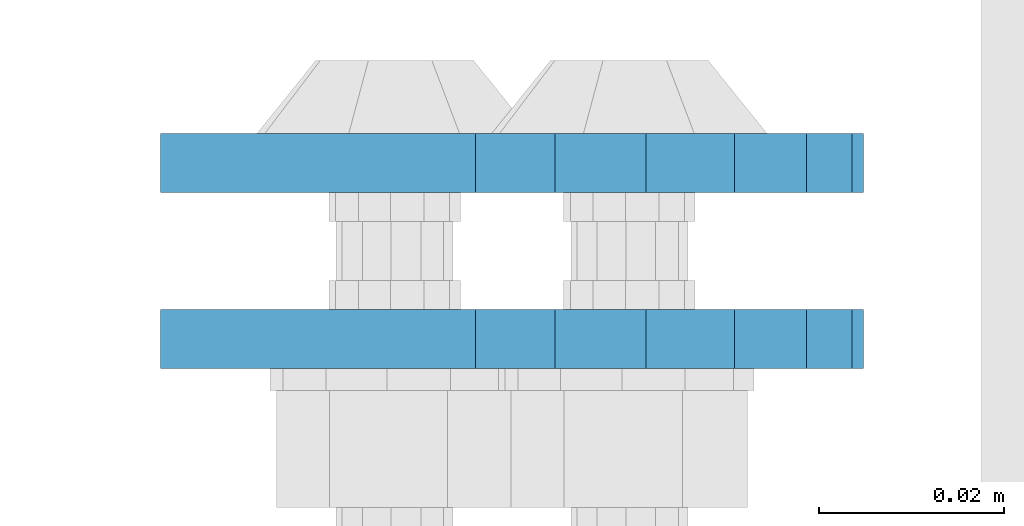
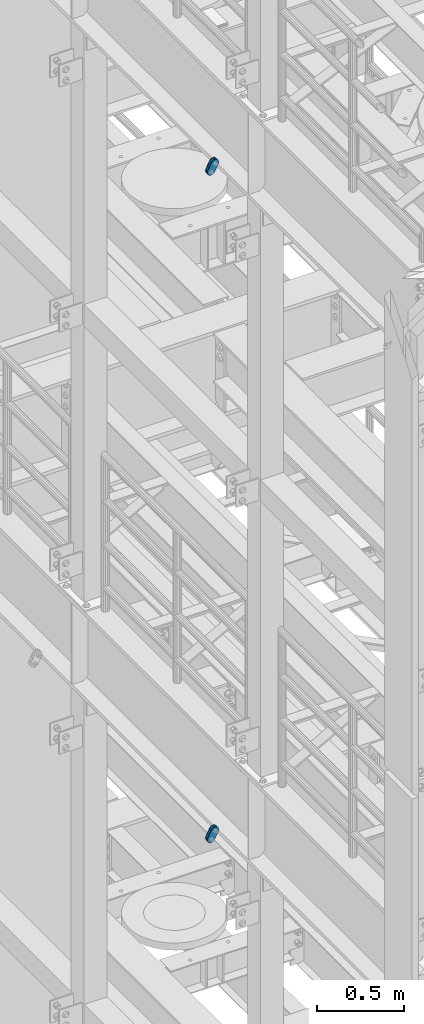
# One storey, part 1478 of 1876: 4 plates, 4 elements without a shape of their own.
"""IFC2X3 building model written with IfcOpenShell, lengths in millimetres."""

from ifc_helpers import new_model, si_unit, frame, origin_with_axes, place, context, subcontext, project, spatial, faceted_brep, material, type_object, element, aggregate, save


model = new_model("IFC2X3")

# Units and contexts
model_context = context("Model", 3, precision=1e-05, world=origin_with_axes())
body_context = subcontext(model_context, "Body", "Model", "MODEL_VIEW")
ifc_project = project(units=[si_unit("LENGTHUNIT", "METRE", prefix="MILLI"), si_unit("AREAUNIT", "SQUARE_METRE"), si_unit("VOLUMEUNIT", "CUBIC_METRE"), si_unit("MASSUNIT", "GRAM", prefix="KILO"), si_unit("TIMEUNIT", "SECOND"), si_unit("PLANEANGLEUNIT", "RADIAN"), si_unit("SOLIDANGLEUNIT", "STERADIAN"), si_unit("THERMODYNAMICTEMPERATUREUNIT", "DEGREE_CELSIUS"), si_unit("LUMINOUSINTENSITYUNIT", "LUMEN")], contexts=[model_context])

# Site, building, storey
site_placement = place(None, origin_with_axes())
site = spatial("IfcSite", under=ifc_project, at=site_placement, CompositionType="ELEMENT")
building_placement = place(site_placement, origin_with_axes())
building = spatial("IfcBuilding", under=site, at=building_placement, Name="Undefined", CompositionType="ELEMENT")
storey_placement = place(building_placement, origin_with_axes())
storey = spatial("IfcBuildingStorey", under=building, at=storey_placement, Name="Undefined", CompositionType="ELEMENT", Elevation=0.0)

# Assembly, plate
assembly_1_placement = place(storey_placement, origin_with_axes())
assembly_1 = element("IfcElementAssembly", 1, at=assembly_1_placement, inside=storey, Name="PLATE", AssemblyPlace="NOTDEFINED", PredefinedType="RIGID_FRAME")
ifc_material = material(Name="STEEL/A36")
plate_type = type_object("IfcPlateType", PredefinedType="NOTDEFINED")
plate_1_placement = place(assembly_1_placement, frame((-354.259224851122, -2549.5249946794, 17725.1776774809), z_axis=(0.894427191199916, 0.0, -0.447213595099958), x_axis=(-0.447213595099961, 6.99999707257306e-09, -0.894427191199915)))
plate_1 = element("IfcPlate", 2, at=plate_1_placement, type_object=plate_type, material=ifc_material, Name="PLATE", context=body_context, shape_type="Brep", body=[
    faceted_brep([(-8.59611645864788e-07, -3.17499999999654, 25.3999987589127), (1.93345873884391, -3.17499999999382, 35.1201580589886), (1.93345873884391, 3.17500000000564, 35.1201580589886), (-8.59611645864788e-07, 3.17500000000382, 25.3999987589132), (7.43948648259902, -3.17499999999109, 43.3605112870105), (7.43948648259902, 3.17500000000928, 43.3605112870105), (15.6798395242777, -3.17499999998654, 48.8665393096448), (15.6798395242777, 3.17500000001382, 48.8665393096448), (25.3999987589095, -3.17499999998199, 50.7999992370592), (25.3999987589095, 3.17500000001837, 50.7999992370592), (82.196130752618, -3.17499999998381, 50.7999992370605), (82.196130752618, 3.17500000001655, 50.7999992370642), (91.9162897887145, -3.17499999997926, 48.8665393918873), (91.9162897887145, 3.1750000000211, 48.8665393918909), (100.156642725027, -3.17499999997472, 43.3605115909359), (100.156642725027, 3.17500000002565, 43.3605115909395), (105.662670525982, -3.17499999997108, 35.1201586546285), (105.662670525986, 3.17500000002929, 35.1201586546358), (107.596130371159, -3.17499999996744, 25.3999996185757), (107.596130371159, 3.17500000003292, 25.3999996185794), (105.662670525981, -3.17499999996471, 15.6798405824902), (105.662670525981, 3.17500000003565, 15.6798405824939), (100.156642725024, -3.17499999996471, 7.43948764618654), (100.156642725025, 3.17500000003565, 7.43948764619017), (91.9162897887127, -3.17499999996562, 1.93345984522784), (91.9162897887127, 3.17500000003474, 1.93345984523148), (82.196130752618, -3.17499999996835, 4.54747350886464e-11), (82.196130752618, 3.1750000000311, 4.91127138957381e-11), (25.399998758905, -3.17499999999018, -8.64019966684282e-12), (25.399998758905, 3.17500000001019, -8.64019966684282e-12), (15.679839921364, -3.17499999999382, 1.9334597629304), (15.679839921364, 3.17500000000655, 1.9334597629304), (7.43948709043525, -3.17499999999654, 7.43948734220839), (7.43948709043525, 3.17500000000382, 7.43948734220885), (1.93345923228208, -3.17499999999654, 15.6798399868012), (1.93345923228208, 3.17500000000291, 15.6798399868012)], [[[0, 1, 2, 3]], [[1, 4, 5, 2]], [[4, 6, 7, 5]], [[6, 8, 9, 7]], [[8, 10, 11, 9]], [[10, 12, 13, 11]], [[12, 14, 15, 13]], [[14, 16, 17, 15]], [[16, 18, 19, 17]], [[18, 20, 21, 19]], [[20, 22, 23, 21]], [[22, 24, 25, 23]], [[24, 26, 27, 25]], [[26, 28, 29, 27]], [[28, 30, 31, 29]], [[30, 32, 33, 31]], [[32, 34, 35, 33]], [[34, 0, 3, 35]], [[5, 7, 9, 11, 13, 15, 17, 19, 21, 23, 25, 27, 29, 31, 33, 35, 3, 2]], [[34, 32, 30, 28, 26, 24, 22, 20, 18, 16, 14, 12, 10, 8, 6, 4, 1, 0]]]),
])
aggregate(assembly_1, [plate_1])

assembly_2_placement = place(storey_placement, origin_with_axes())
assembly_2 = element("IfcElementAssembly", 3, at=assembly_2_placement, inside=storey, Name="PLATE", AssemblyPlace="NOTDEFINED", PredefinedType="RIGID_FRAME")
plate_2_placement = place(assembly_2_placement, frame((-354.259224851122, -2530.46379837472, 17725.1776774809), z_axis=(0.894427191199916, 0.0, -0.447213595099958), x_axis=(-0.447213595099961, 6.99999707257306e-09, -0.894427191199915)))
plate_2 = element("IfcPlate", 4, at=plate_2_placement, type_object=plate_type, material=ifc_material, Name="PLATE", context=body_context, shape_type="Brep", body=[
    faceted_brep([(-8.59611645864788e-07, -3.17499999999654, 25.3999987589127), (1.93345873884391, -3.17499999999382, 35.1201580589886), (1.93345873884391, 3.17500000000564, 35.1201580589886), (-8.59611645864788e-07, 3.17500000000382, 25.3999987589132), (7.43948648259902, -3.17499999999109, 43.3605112870105), (7.43948648259902, 3.17500000000928, 43.3605112870105), (15.6798395242777, -3.17499999998654, 48.8665393096448), (15.6798395242777, 3.17500000001382, 48.8665393096448), (25.3999987589095, -3.17499999998199, 50.7999992370592), (25.3999987589095, 3.17500000001837, 50.7999992370592), (82.196130752618, -3.17499999998381, 50.7999992370605), (82.196130752618, 3.17500000001655, 50.7999992370642), (91.9162897887145, -3.17499999997926, 48.8665393918873), (91.9162897887145, 3.1750000000211, 48.8665393918909), (100.156642725027, -3.17499999997472, 43.3605115909359), (100.156642725027, 3.17500000002565, 43.3605115909395), (105.662670525982, -3.17499999997108, 35.1201586546285), (105.662670525986, 3.17500000002929, 35.1201586546358), (107.596130371159, -3.17499999996744, 25.3999996185757), (107.596130371159, 3.17500000003292, 25.3999996185794), (105.662670525981, -3.17499999996471, 15.6798405824902), (105.662670525981, 3.17500000003565, 15.6798405824939), (100.156642725024, -3.17499999996471, 7.43948764618654), (100.156642725025, 3.17500000003565, 7.43948764619017), (91.9162897887127, -3.17499999996562, 1.93345984522784), (91.9162897887127, 3.17500000003474, 1.93345984523148), (82.196130752618, -3.17499999996835, 4.54747350886464e-11), (82.196130752618, 3.1750000000311, 4.91127138957381e-11), (25.399998758905, -3.17499999999018, -8.64019966684282e-12), (25.399998758905, 3.17500000001019, -8.64019966684282e-12), (15.679839921364, -3.17499999999382, 1.9334597629304), (15.679839921364, 3.17500000000655, 1.9334597629304), (7.43948709043525, -3.17499999999654, 7.43948734220839), (7.43948709043525, 3.17500000000382, 7.43948734220885), (1.93345923228208, -3.17499999999654, 15.6798399868012), (1.93345923228208, 3.17500000000291, 15.6798399868012)], [[[0, 1, 2, 3]], [[1, 4, 5, 2]], [[4, 6, 7, 5]], [[6, 8, 9, 7]], [[8, 10, 11, 9]], [[10, 12, 13, 11]], [[12, 14, 15, 13]], [[14, 16, 17, 15]], [[16, 18, 19, 17]], [[18, 20, 21, 19]], [[20, 22, 23, 21]], [[22, 24, 25, 23]], [[24, 26, 27, 25]], [[26, 28, 29, 27]], [[28, 30, 31, 29]], [[30, 32, 33, 31]], [[32, 34, 35, 33]], [[34, 0, 3, 35]], [[5, 7, 9, 11, 13, 15, 17, 19, 21, 23, 25, 27, 29, 31, 33, 35, 3, 2]], [[34, 32, 30, 28, 26, 24, 22, 20, 18, 16, 14, 12, 10, 8, 6, 4, 1, 0]]]),
])
aggregate(assembly_2, [plate_2])

assembly_3_placement = place(storey_placement, origin_with_axes())
assembly_3 = element("IfcElementAssembly", 5, at=assembly_3_placement, inside=storey, Name="PLATE", AssemblyPlace="NOTDEFINED", PredefinedType="RIGID_FRAME")
plate_3_placement = place(assembly_3_placement, frame((-354.259224851122, -2549.5249946794, 13038.8776774809), z_axis=(0.894427191199916, 0.0, -0.447213595099958), x_axis=(-0.447213595099961, 6.99999707257306e-09, -0.894427191199915)))
plate_3 = element("IfcPlate", 6, at=plate_3_placement, type_object=plate_type, material=ifc_material, Name="PLATE", context=body_context, shape_type="Brep", body=[
    faceted_brep([(-8.59611645864788e-07, -3.17499999999654, 25.3999987589127), (1.93345873884391, -3.17499999999382, 35.1201580589886), (1.93345873884391, 3.17500000000564, 35.1201580589886), (-8.59611645864788e-07, 3.17500000000382, 25.3999987589132), (7.43948648259902, -3.17499999999109, 43.3605112870105), (7.43948648259902, 3.17500000000928, 43.3605112870105), (15.6798395242777, -3.17499999998654, 48.8665393096448), (15.6798395242777, 3.17500000001382, 48.8665393096448), (25.3999987589095, -3.17499999998199, 50.7999992370592), (25.3999987589095, 3.17500000001837, 50.7999992370592), (82.196130752618, -3.17499999998381, 50.7999992370605), (82.196130752618, 3.17500000001655, 50.7999992370642), (91.9162897887145, -3.17499999997926, 48.8665393918873), (91.9162897887145, 3.1750000000211, 48.8665393918909), (100.156642725027, -3.17499999997472, 43.3605115909359), (100.156642725027, 3.17500000002565, 43.3605115909395), (105.662670525982, -3.17499999997108, 35.1201586546285), (105.662670525986, 3.17500000002929, 35.1201586546358), (107.596130371159, -3.17499999996744, 25.3999996185757), (107.596130371159, 3.17500000003292, 25.3999996185794), (105.662670525981, -3.17499999996471, 15.6798405824902), (105.662670525981, 3.17500000003565, 15.6798405824939), (100.156642725024, -3.17499999996471, 7.43948764618654), (100.156642725025, 3.17500000003565, 7.43948764619017), (91.9162897887127, -3.17499999996562, 1.93345984522784), (91.9162897887127, 3.17500000003474, 1.93345984523148), (82.196130752618, -3.17499999996835, 4.54747350886464e-11), (82.196130752618, 3.1750000000311, 4.91127138957381e-11), (25.399998758905, -3.17499999999018, -8.64019966684282e-12), (25.399998758905, 3.17500000001019, -8.64019966684282e-12), (15.679839921364, -3.17499999999382, 1.9334597629304), (15.679839921364, 3.17500000000655, 1.9334597629304), (7.43948709043525, -3.17499999999654, 7.43948734220839), (7.43948709043525, 3.17500000000382, 7.43948734220885), (1.93345923228208, -3.17499999999654, 15.6798399868012), (1.93345923228208, 3.17500000000291, 15.6798399868012)], [[[0, 1, 2, 3]], [[1, 4, 5, 2]], [[4, 6, 7, 5]], [[6, 8, 9, 7]], [[8, 10, 11, 9]], [[10, 12, 13, 11]], [[12, 14, 15, 13]], [[14, 16, 17, 15]], [[16, 18, 19, 17]], [[18, 20, 21, 19]], [[20, 22, 23, 21]], [[22, 24, 25, 23]], [[24, 26, 27, 25]], [[26, 28, 29, 27]], [[28, 30, 31, 29]], [[30, 32, 33, 31]], [[32, 34, 35, 33]], [[34, 0, 3, 35]], [[5, 7, 9, 11, 13, 15, 17, 19, 21, 23, 25, 27, 29, 31, 33, 35, 3, 2]], [[34, 32, 30, 28, 26, 24, 22, 20, 18, 16, 14, 12, 10, 8, 6, 4, 1, 0]]]),
])
aggregate(assembly_3, [plate_3])

assembly_4_placement = place(storey_placement, origin_with_axes())
assembly_4 = element("IfcElementAssembly", 7, at=assembly_4_placement, inside=storey, Name="PLATE", AssemblyPlace="NOTDEFINED", PredefinedType="RIGID_FRAME")
plate_4_placement = place(assembly_4_placement, frame((-354.259224851122, -2530.46379837472, 13038.8776774809), z_axis=(0.894427191199916, 0.0, -0.447213595099958), x_axis=(-0.447213595099961, 6.99999707257306e-09, -0.894427191199915)))
plate_4 = element("IfcPlate", 8, at=plate_4_placement, type_object=plate_type, material=ifc_material, Name="PLATE", context=body_context, shape_type="Brep", body=[
    faceted_brep([(-8.59611645864788e-07, -3.17499999999654, 25.3999987589127), (1.93345873884391, -3.17499999999382, 35.1201580589886), (1.93345873884391, 3.17500000000564, 35.1201580589886), (-8.59611645864788e-07, 3.17500000000382, 25.3999987589132), (7.43948648259902, -3.17499999999109, 43.3605112870105), (7.43948648259902, 3.17500000000928, 43.3605112870105), (15.6798395242777, -3.17499999998654, 48.8665393096448), (15.6798395242777, 3.17500000001382, 48.8665393096448), (25.3999987589095, -3.17499999998199, 50.7999992370592), (25.3999987589095, 3.17500000001837, 50.7999992370592), (82.196130752618, -3.17499999998381, 50.7999992370605), (82.196130752618, 3.17500000001655, 50.7999992370642), (91.9162897887145, -3.17499999997926, 48.8665393918873), (91.9162897887145, 3.1750000000211, 48.8665393918909), (100.156642725027, -3.17499999997472, 43.3605115909359), (100.156642725027, 3.17500000002565, 43.3605115909395), (105.662670525982, -3.17499999997108, 35.1201586546285), (105.662670525986, 3.17500000002929, 35.1201586546358), (107.596130371159, -3.17499999996744, 25.3999996185757), (107.596130371159, 3.17500000003292, 25.3999996185794), (105.662670525981, -3.17499999996471, 15.6798405824902), (105.662670525981, 3.17500000003565, 15.6798405824939), (100.156642725024, -3.17499999996471, 7.43948764618654), (100.156642725025, 3.17500000003565, 7.43948764619017), (91.9162897887127, -3.17499999996562, 1.93345984522784), (91.9162897887127, 3.17500000003474, 1.93345984523148), (82.196130752618, -3.17499999996835, 4.54747350886464e-11), (82.196130752618, 3.1750000000311, 4.91127138957381e-11), (25.399998758905, -3.17499999999018, -8.64019966684282e-12), (25.399998758905, 3.17500000001019, -8.64019966684282e-12), (15.679839921364, -3.17499999999382, 1.9334597629304), (15.679839921364, 3.17500000000655, 1.9334597629304), (7.43948709043525, -3.17499999999654, 7.43948734220839), (7.43948709043525, 3.17500000000382, 7.43948734220885), (1.93345923228208, -3.17499999999654, 15.6798399868012), (1.93345923228208, 3.17500000000291, 15.6798399868012)], [[[0, 1, 2, 3]], [[1, 4, 5, 2]], [[4, 6, 7, 5]], [[6, 8, 9, 7]], [[8, 10, 11, 9]], [[10, 12, 13, 11]], [[12, 14, 15, 13]], [[14, 16, 17, 15]], [[16, 18, 19, 17]], [[18, 20, 21, 19]], [[20, 22, 23, 21]], [[22, 24, 25, 23]], [[24, 26, 27, 25]], [[26, 28, 29, 27]], [[28, 30, 31, 29]], [[30, 32, 33, 31]], [[32, 34, 35, 33]], [[34, 0, 3, 35]], [[5, 7, 9, 11, 13, 15, 17, 19, 21, 23, 25, 27, 29, 31, 33, 35, 3, 2]], [[34, 32, 30, 28, 26, 24, 22, 20, 18, 16, 14, 12, 10, 8, 6, 4, 1, 0]]]),
])
aggregate(assembly_4, [plate_4])

save(model, "model.ifc")
